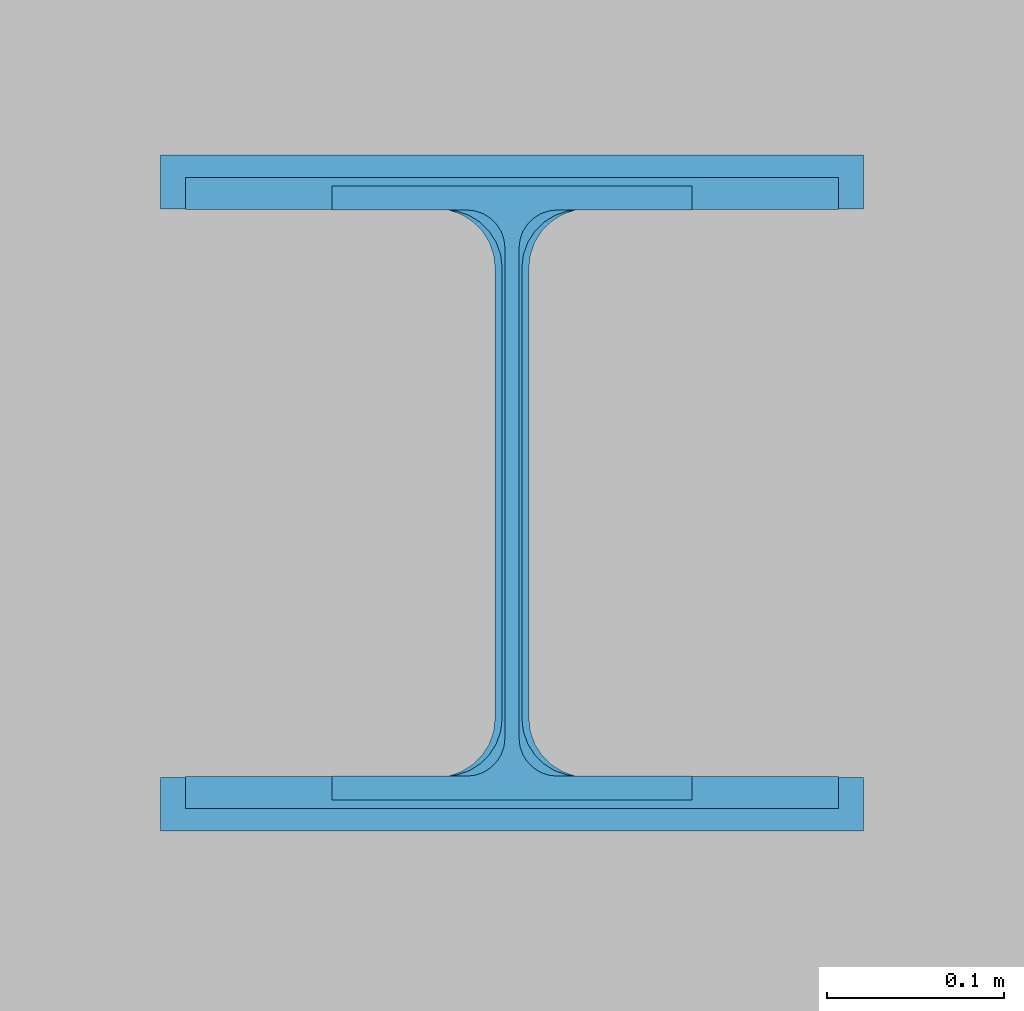
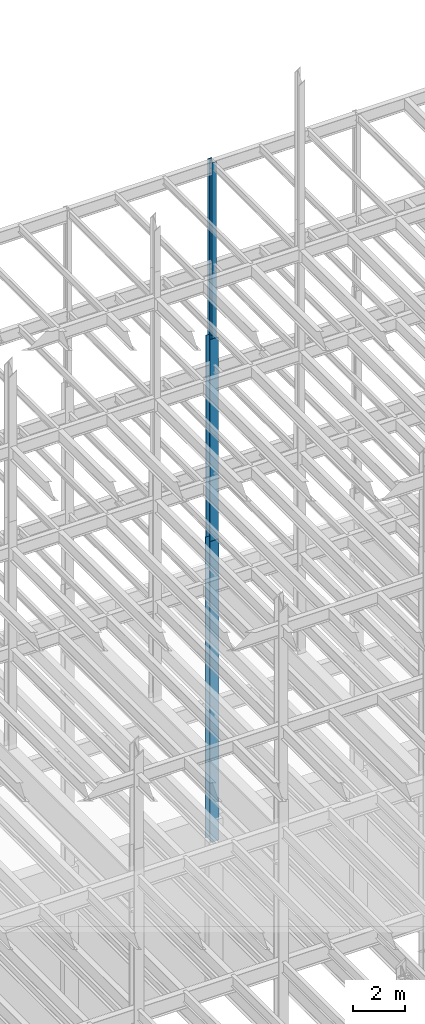
# One storey, part 64 of 150: 3 columns.
"""IFC2X3 building model written with IfcOpenShell, lengths in millimetres."""

from ifc_helpers import new_model, si_unit, frame, origin_with_axes, origin_2d_with_axis, place, context, subcontext, project, spatial, i_section, extrude, material, type_object, element, save


model = new_model("IFC2X3")

# Units and contexts
model_context = context("Model", 3, precision=1e-05, world=origin_with_axes())
body_context = subcontext(model_context, "Body", "Model", "MODEL_VIEW")
ifc_project = project(units=[si_unit("LENGTHUNIT", "METRE", prefix="MILLI"), si_unit("AREAUNIT", "SQUARE_METRE"), si_unit("VOLUMEUNIT", "CUBIC_METRE"), si_unit("MASSUNIT", "GRAM", prefix="KILO"), si_unit("TIMEUNIT", "SECOND"), si_unit("PLANEANGLEUNIT", "RADIAN"), si_unit("SOLIDANGLEUNIT", "STERADIAN"), si_unit("THERMODYNAMICTEMPERATUREUNIT", "DEGREE_CELSIUS"), si_unit("LUMINOUSINTENSITYUNIT", "LUMEN")], contexts=[model_context])

# Site, building, storey
site_placement = place(None, origin_with_axes())
site = spatial("IfcSite", under=ifc_project, at=site_placement, CompositionType="ELEMENT")
building_placement = place(site_placement, origin_with_axes())
building = spatial("IfcBuilding", under=site, at=building_placement, Name="Undefined", CompositionType="ELEMENT")
storey_placement = place(building_placement, origin_with_axes())
storey = spatial("IfcBuildingStorey", under=building, at=storey_placement, Name="Undefined", CompositionType="ELEMENT", Elevation=0.0)

# Columns
ifc_material = material(Name="STEEL/A992")
column_type_1 = type_object("IfcColumnType", Name="W14X43", PredefinedType="NOTDEFINED")
column_1_placement = place(storey_placement, frame((37388.8, 38862.0, 46253.4), z_axis=(0.0, 0.0, 1.0), x_axis=(1.0, 0.0, 0.0)))
element("IfcColumn", 1, at=column_1_placement, inside=storey, type_object=column_type_1, material=ifc_material, Name="COLUMN", ObjectType="W14X43", context=body_context, shape_type="SweptSolid", body=[
    extrude(i_section(OverallWidth=203.2, OverallDepth=346.075, WebThickness=7.9375, FlangeThickness=13.462, FilletRadius=21.4629, at=origin_2d_with_axis()), frame((0.0, 0.0, 8229.60000000002), z_axis=(0.0, 0.0, -1.0), x_axis=(-1.0, 0.0, 0.0)), (0.0, 0.0, 1.0), 8229.60000000002),
])
column_type_2 = type_object("IfcColumnType", Name="W14X90", PredefinedType="NOTDEFINED")
column_2_placement = place(storey_placement, frame((37388.8, 38862.0, 36804.6012877801), z_axis=(0.0, 0.0, 1.0), x_axis=(1.0, 0.0, 0.0)))
element("IfcColumn", 2, at=column_2_placement, inside=storey, type_object=column_type_2, material=ifc_material, Name="COLUMN", ObjectType="W14X90", context=body_context, shape_type="SweptSolid", body=[
    extrude(i_section(OverallWidth=368.3, OverallDepth=355.6, WebThickness=11.1125, FlangeThickness=18.034, FilletRadius=32.7659, at=origin_2d_with_axis()), frame((0.0, 0.0, 9448.79776734), z_axis=(0.0, 0.0, -1.0), x_axis=(-1.0, 0.0, 0.0)), (0.0, 0.0, 1.0), 9448.79776734),
])
column_type_3 = type_object("IfcColumnType", Name="W14X159", PredefinedType="NOTDEFINED")
column_3_placement = place(storey_placement, frame((37388.8, 38862.0, 22707.6), z_axis=(0.0, 0.0, 1.0), x_axis=(1.0, 0.0, 0.0)))
element("IfcColumn", 3, at=column_3_placement, inside=storey, type_object=column_type_3, material=ifc_material, Name="COLUMN", ObjectType="W14X159", context=body_context, shape_type="SweptSolid", body=[
    extrude(i_section(OverallWidth=396.24, OverallDepth=381.0, WebThickness=19.0499, FlangeThickness=30.226, FilletRadius=33.2739, at=origin_2d_with_axis()), frame((0.0, 0.0, 14097.0012877801), z_axis=(0.0, 0.0, -1.0), x_axis=(-1.0, 0.0, 0.0)), (0.0, 0.0, 1.0), 14097.0012877801),
])

save(model, "model.ifc")
